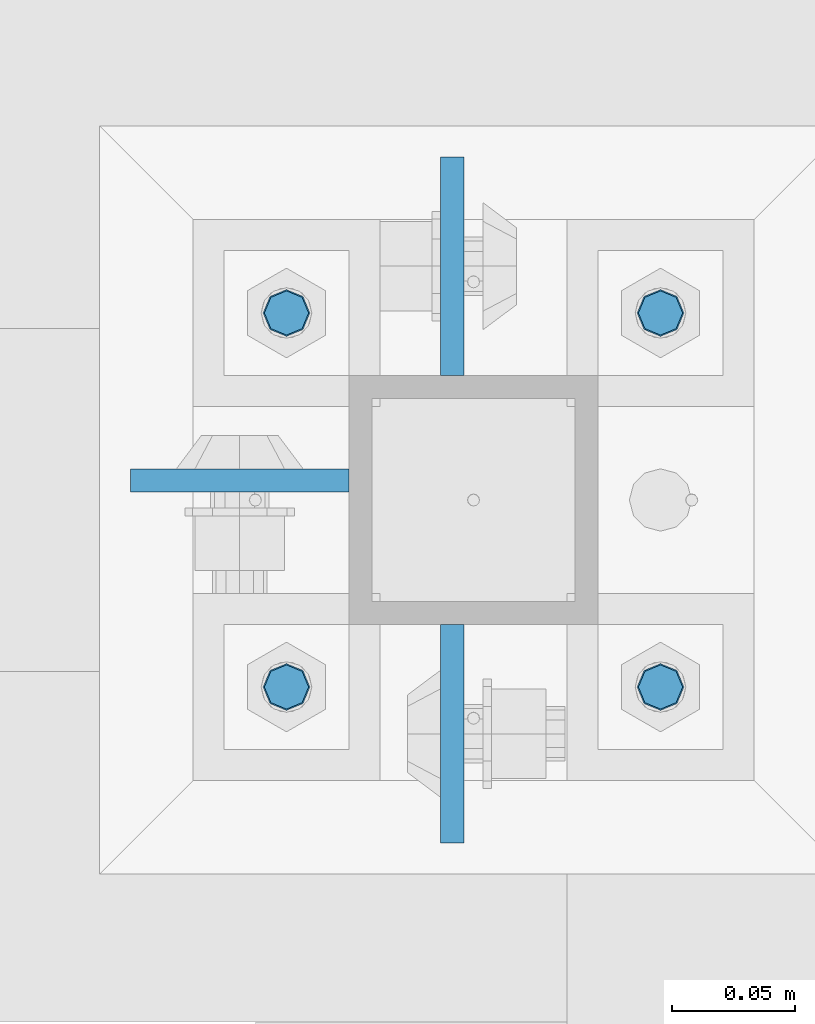
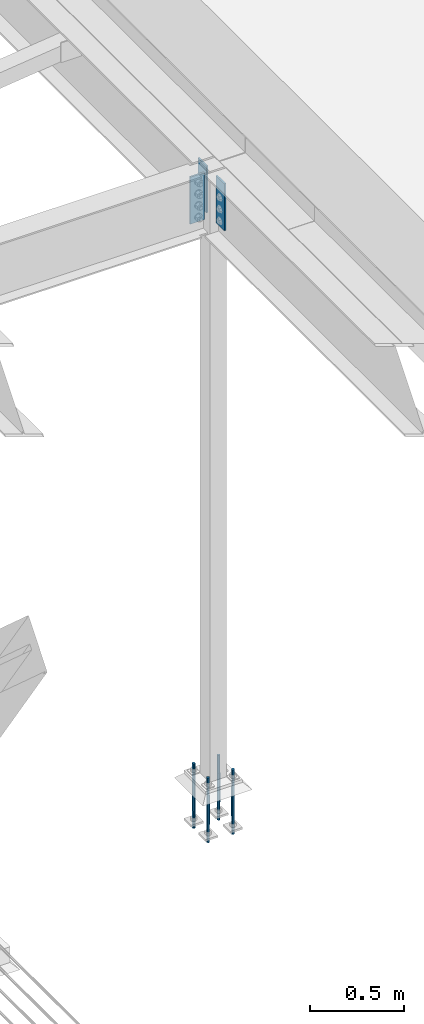
# One storey, part 1557 of 3843: 7 columns, 2 elements without a shape of their own.
"""IFC2X3 building model written with IfcOpenShell, lengths in millimetres."""

from ifc_helpers import new_model, si_unit, frame, origin_with_axes, place, context, subcontext, project, spatial, faceted_brep, material, type_object, element, aggregate, save


model = new_model("IFC2X3")

# Units and contexts
model_context = context("Model", 3, precision=1e-05, world=origin_with_axes())
body_context = subcontext(model_context, "Body", "Model", "MODEL_VIEW")
ifc_project = project(units=[si_unit("LENGTHUNIT", "METRE", prefix="MILLI"), si_unit("AREAUNIT", "SQUARE_METRE"), si_unit("VOLUMEUNIT", "CUBIC_METRE"), si_unit("MASSUNIT", "GRAM", prefix="KILO"), si_unit("TIMEUNIT", "SECOND"), si_unit("PLANEANGLEUNIT", "RADIAN"), si_unit("SOLIDANGLEUNIT", "STERADIAN"), si_unit("THERMODYNAMICTEMPERATUREUNIT", "DEGREE_CELSIUS"), si_unit("LUMINOUSINTENSITYUNIT", "LUMEN")], contexts=[model_context])

# Site, building, storey
site_placement = place(None, origin_with_axes())
site = spatial("IfcSite", under=ifc_project, at=site_placement, CompositionType="ELEMENT")
building_placement = place(site_placement, origin_with_axes())
building = spatial("IfcBuilding", under=site, at=building_placement, Name="Undefined", CompositionType="ELEMENT")
storey_placement = place(building_placement, origin_with_axes())
storey = spatial("IfcBuildingStorey", under=building, at=storey_placement, Name="Undefined", CompositionType="ELEMENT", Elevation=0.0)

# Assembly, columns
assembly_1_placement = place(storey_placement, origin_with_axes())
assembly_1 = element("IfcElementAssembly", 1, at=assembly_1_placement, inside=storey, Name="COLUMN", AssemblyPlace="NOTDEFINED", PredefinedType="RIGID_FRAME")
ifc_material_1 = material(Name="STEEL/A572-50")
column_type_1 = type_object("IfcColumnType", PredefinedType="NOTDEFINED")
column_1_placement = place(assembly_1_placement, frame((38811.9945000649, 75533.25, 33693.0999993376), z_axis=(0.0, 1.0, 0.0), x_axis=(0.0, 0.0, 1.0)))
column_1 = element("IfcColumn", 2, at=column_1_placement, type_object=column_type_1, material=ifc_material_1, Name="PLATE", context=body_context, shape_type="Brep", body=[
    faceted_brep([(0.0, 4.76249999999709, -44.4500000000007), (0.0, 4.76249999999709, 44.4500000000007), (304.799999999996, 4.76249999999709, 44.4500000000007), (304.799999999996, 4.76249999999709, -44.4500000000007), (0.0, -4.76249999999709, 44.4500000000007), (304.799999999996, -4.76249999999709, 44.4500000000007), (0.0, -4.76249999999709, -44.4500000000007), (304.799999999996, -4.76249999999709, -44.4500000000007)], [[[0, 1, 2, 3]], [[1, 4, 5, 2]], [[4, 6, 7, 5]], [[6, 0, 3, 7]], [[5, 7, 3, 2]], [[6, 4, 1, 0]]]),
])
column_2_placement = place(assembly_1_placement, frame((38811.9945000649, 75723.75, 33693.0999993376), z_axis=(0.0, -1.0, 0.0), x_axis=(0.0, 0.0, 1.0)))
column_2 = element("IfcColumn", 3, at=column_2_placement, type_object=column_type_1, material=ifc_material_1, Name="PLATE", context=body_context, shape_type="Brep", body=[
    faceted_brep([(0.0, 4.76249999999709, -44.4500000000007), (0.0, 4.76249999999709, 44.4500000000007), (304.799999999996, 4.76249999999709, 44.4500000000007), (304.799999999996, 4.76249999999709, -44.4500000000007), (0.0, -4.76249999999709, 44.4500000000007), (304.799999999996, -4.76249999999709, 44.4500000000007), (0.0, -4.76249999999709, -44.4500000000007), (304.799999999996, -4.76249999999709, -44.4500000000007)], [[[0, 1, 2, 3]], [[1, 4, 5, 2]], [[4, 6, 7, 5]], [[6, 0, 3, 7]], [[5, 7, 3, 2]], [[6, 4, 1, 0]]]),
])
column_3_placement = place(assembly_1_placement, frame((38725.475, 75636.4374999523, 33693.1), z_axis=(1.0, 0.0, 0.0), x_axis=(0.0, 0.0, 1.0)))
column_3 = element("IfcColumn", 4, at=column_3_placement, type_object=column_type_1, material=ifc_material_1, Name="PLATE", context=body_context, shape_type="Brep", body=[
    faceted_brep([(0.0, 4.76249999999709, -44.4500000000007), (0.0, 4.76249999999709, 44.4500000000007), (304.799999999996, 4.76249999999709, 44.4500000000007), (304.799999999996, 4.76249999999709, -44.4500000000007), (0.0, -4.76249999999709, 44.4500000000007), (304.799999999996, -4.76249999999709, 44.4500000000007), (0.0, -4.76249999999709, -44.4500000000007), (304.799999999996, -4.76249999999709, -44.4500000000007)], [[[0, 1, 2, 3]], [[1, 4, 5, 2]], [[4, 6, 7, 5]], [[6, 0, 3, 7]], [[5, 7, 3, 2]], [[6, 4, 1, 0]]]),
])
aggregate(assembly_1, [column_1, column_2, column_3])

assembly_2_placement = place(storey_placement, origin_with_axes())
assembly_2 = element("IfcElementAssembly", 5, at=assembly_2_placement, inside=storey, Name="TEMPLATE", AssemblyPlace="NOTDEFINED", PredefinedType="RIGID_FRAME")
ifc_material_2 = material(Name="Undefined/F1554-GR.55")
column_type_2 = type_object("IfcColumnType", PredefinedType="NOTDEFINED")
column_4_placement = place(assembly_2_placement, frame((38896.925, 75552.3, 30022.8), z_axis=(1.0, 0.0, 0.0), x_axis=(0.0, 0.0, -1.0)))
column_4 = element("IfcColumn", 6, at=column_4_placement, type_object=column_type_2, material=ifc_material_2, Name="ANCHOR_ROD", context=body_context, shape_type="Brep", body=[
    faceted_brep([(-114.300000000003, -6.36396103068546, 6.36396103067818), (-114.300000000003, 0.0, 9.0), (-114.300000000003, 6.36396103068546, 6.36396103067818), (-114.300000000003, 9.0, 0.0), (-114.300000000003, 6.36396103068546, -6.36396103067818), (-114.300000000003, 0.0, -9.0), (-114.300000000003, -6.36396103068546, -6.36396103067818), (-114.300000000003, -9.0, 0.0), (0.0, 6.36396103068546, -6.36396103067818), (0.0, 0.0, -9.0), (0.0, -6.36396103068546, -6.36396103067818), (0.0, -9.0, 0.0), (0.0, -6.36396103068546, 6.36396103067818), (0.0, 0.0, 9.0), (0.0, 6.36396103068546, 6.36396103067818), (0.0, 9.0, 0.0), (0.0, -6.73519209080405, 6.73519209079677), (-9.87109982941227e-13, 2.91322521661641e-12, 9.52499961853027), (0.0, 6.73519209080405, 6.73519209079677), (0.0, 9.52500000000146, 0.0), (0.0, 6.73519209080405, -6.73519209079677), (2.95075507493764e-12, 2.91322521661641e-12, -9.52499961853027), (0.0, -6.73519209080405, -6.73519209079677), (0.0, -9.52500000000146, 0.0), (190.5, -9.52499999999418, 0.0), (190.5, -6.73519209079677, 6.73519209080405), (190.5, 0.0, 9.52500000000146), (190.5, 6.73519209079677, 6.73519209080405), (190.5, 9.52499999999418, 0.0), (190.5, 6.73519209079677, -6.73519209080405), (190.5, 0.0, -9.52500000000146), (190.5, -6.73519209079677, -6.73519209080405), (190.5, -6.36396103068546, 6.36396103067818), (190.5, 0.0, 9.0), (190.5, 6.36396103068546, 6.36396103067818), (190.5, 9.0, 0.0), (190.5, 6.36396103068546, -6.36396103067818), (190.5, 0.0, -9.0), (190.5, -6.36396103068546, -6.36396103067818), (190.5, -9.0, 0.0), (304.799999999999, 0.0, -9.0), (304.799999999999, 6.36396103068546, -6.36396103067818), (304.799999999999, 9.0, 0.0), (304.799999999999, 6.36396103068546, 6.36396103067818), (304.799999999999, 0.0, 9.0), (304.799999999999, -6.36396103068546, 6.36396103067818), (304.799999999999, -9.0, 0.0), (304.799999999999, -6.36396103068546, -6.36396103067818)], [[[0, 1, 2, 3, 4, 5, 6, 7]], [[5, 4, 8, 9]], [[6, 5, 9, 10]], [[7, 6, 10, 11]], [[0, 7, 11, 12]], [[1, 0, 12, 13]], [[2, 1, 13, 14]], [[3, 2, 14, 15]], [[4, 3, 15, 8]], [[16, 17, 18, 19, 20, 21, 22, 23], [14, 13, 12, 11, 10, 9, 8, 15]], [[16, 23, 24, 25]], [[17, 16, 25, 26]], [[18, 17, 26, 27]], [[19, 18, 27, 28]], [[20, 19, 28, 29]], [[21, 20, 29, 30]], [[22, 21, 30, 31]], [[23, 22, 31, 24]], [[30, 29, 28, 27, 26, 25, 24, 31], [32, 33, 34, 35, 36, 37, 38, 39]], [[40, 41, 42, 43, 44, 45, 46, 47]], [[45, 44, 33, 32]], [[46, 45, 32, 39]], [[47, 46, 39, 38]], [[40, 47, 38, 37]], [[41, 40, 37, 36]], [[42, 41, 36, 35]], [[43, 42, 35, 34]], [[44, 43, 34, 33]]]),
])
column_5_placement = place(assembly_2_placement, frame((38896.925, 75704.7, 30022.8), z_axis=(-1.0, 0.0, 0.0), x_axis=(0.0, 0.0, -1.0)))
column_5 = element("IfcColumn", 7, at=column_5_placement, type_object=column_type_2, material=ifc_material_2, Name="ANCHOR_ROD", context=body_context, shape_type="Brep", body=[
    faceted_brep([(-114.300000000003, -6.36396103068546, 6.36396103067818), (-114.300000000003, 0.0, 9.0), (-114.300000000003, 6.36396103068546, 6.36396103067818), (-114.300000000003, 9.0, 0.0), (-114.300000000003, 6.36396103068546, -6.36396103067818), (-114.300000000003, 0.0, -9.0), (-114.300000000003, -6.36396103068546, -6.36396103067818), (-114.300000000003, -9.0, 0.0), (0.0, 6.36396103068546, -6.36396103067818), (0.0, 0.0, -9.0), (0.0, -6.36396103068546, -6.36396103067818), (0.0, -9.0, 0.0), (0.0, -6.36396103068546, 6.36396103067818), (0.0, 0.0, 9.0), (0.0, 6.36396103068546, 6.36396103067818), (0.0, 9.0, 0.0), (0.0, -6.73519209080405, 6.73519209079677), (-9.87109982941227e-13, 2.91322521661641e-12, 9.52499961853027), (0.0, 6.73519209080405, 6.73519209079677), (0.0, 9.52500000000146, 0.0), (0.0, 6.73519209080405, -6.73519209079677), (2.95075507493764e-12, 2.91322521661641e-12, -9.52499961853027), (0.0, -6.73519209080405, -6.73519209079677), (0.0, -9.52500000000146, 0.0), (190.5, -9.52499999999418, 0.0), (190.5, -6.73519209079677, 6.73519209080405), (190.5, 0.0, 9.52500000000146), (190.5, 6.73519209079677, 6.73519209080405), (190.5, 9.52499999999418, 0.0), (190.5, 6.73519209079677, -6.73519209080405), (190.5, 0.0, -9.52500000000146), (190.5, -6.73519209079677, -6.73519209080405), (190.5, -6.36396103068546, 6.36396103067818), (190.5, 0.0, 9.0), (190.5, 6.36396103068546, 6.36396103067818), (190.5, 9.0, 0.0), (190.5, 6.36396103068546, -6.36396103067818), (190.5, 0.0, -9.0), (190.5, -6.36396103068546, -6.36396103067818), (190.5, -9.0, 0.0), (304.799999999999, 0.0, -9.0), (304.799999999999, 6.36396103068546, -6.36396103067818), (304.799999999999, 9.0, 0.0), (304.799999999999, 6.36396103068546, 6.36396103067818), (304.799999999999, 0.0, 9.0), (304.799999999999, -6.36396103068546, 6.36396103067818), (304.799999999999, -9.0, 0.0), (304.799999999999, -6.36396103068546, -6.36396103067818)], [[[0, 1, 2, 3, 4, 5, 6, 7]], [[5, 4, 8, 9]], [[6, 5, 9, 10]], [[7, 6, 10, 11]], [[0, 7, 11, 12]], [[1, 0, 12, 13]], [[2, 1, 13, 14]], [[3, 2, 14, 15]], [[4, 3, 15, 8]], [[16, 17, 18, 19, 20, 21, 22, 23], [14, 13, 12, 11, 10, 9, 8, 15]], [[16, 23, 24, 25]], [[17, 16, 25, 26]], [[18, 17, 26, 27]], [[19, 18, 27, 28]], [[20, 19, 28, 29]], [[21, 20, 29, 30]], [[22, 21, 30, 31]], [[23, 22, 31, 24]], [[30, 29, 28, 27, 26, 25, 24, 31], [32, 33, 34, 35, 36, 37, 38, 39]], [[40, 41, 42, 43, 44, 45, 46, 47]], [[45, 44, 33, 32]], [[46, 45, 32, 39]], [[47, 46, 39, 38]], [[40, 47, 38, 37]], [[41, 40, 37, 36]], [[42, 41, 36, 35]], [[43, 42, 35, 34]], [[44, 43, 34, 33]]]),
])
column_6_placement = place(assembly_2_placement, frame((38744.525, 75552.3, 30022.8), z_axis=(1.0, 0.0, 0.0), x_axis=(0.0, 0.0, -1.0)))
column_6 = element("IfcColumn", 8, at=column_6_placement, type_object=column_type_2, material=ifc_material_2, Name="ANCHOR_ROD", context=body_context, shape_type="Brep", body=[
    faceted_brep([(-114.300000000003, -6.36396103068546, 6.36396103067818), (-114.300000000003, 0.0, 9.0), (-114.300000000003, 6.36396103068546, 6.36396103067818), (-114.300000000003, 9.0, 0.0), (-114.300000000003, 6.36396103068546, -6.36396103067818), (-114.300000000003, 0.0, -9.0), (-114.300000000003, -6.36396103068546, -6.36396103067818), (-114.300000000003, -9.0, 0.0), (0.0, 6.36396103068546, -6.36396103067818), (0.0, 0.0, -9.0), (0.0, -6.36396103068546, -6.36396103067818), (0.0, -9.0, 0.0), (0.0, -6.36396103068546, 6.36396103067818), (0.0, 0.0, 9.0), (0.0, 6.36396103068546, 6.36396103067818), (0.0, 9.0, 0.0), (0.0, -6.73519209080405, 6.73519209079677), (-9.87109982941227e-13, 2.91322521661641e-12, 9.52499961853027), (0.0, 6.73519209080405, 6.73519209079677), (0.0, 9.52500000000146, 0.0), (0.0, 6.73519209080405, -6.73519209079677), (2.95075507493764e-12, 2.91322521661641e-12, -9.52499961853027), (0.0, -6.73519209080405, -6.73519209079677), (0.0, -9.52500000000146, 0.0), (190.5, -9.52499999999418, 0.0), (190.5, -6.73519209079677, 6.73519209080405), (190.5, 0.0, 9.52500000000146), (190.5, 6.73519209079677, 6.73519209080405), (190.5, 9.52499999999418, 0.0), (190.5, 6.73519209079677, -6.73519209080405), (190.5, 0.0, -9.52500000000146), (190.5, -6.73519209079677, -6.73519209080405), (190.5, -6.36396103068546, 6.36396103067818), (190.5, 0.0, 9.0), (190.5, 6.36396103068546, 6.36396103067818), (190.5, 9.0, 0.0), (190.5, 6.36396103068546, -6.36396103067818), (190.5, 0.0, -9.0), (190.5, -6.36396103068546, -6.36396103067818), (190.5, -9.0, 0.0), (304.799999999999, 0.0, -9.0), (304.799999999999, 6.36396103068546, -6.36396103067818), (304.799999999999, 9.0, 0.0), (304.799999999999, 6.36396103068546, 6.36396103067818), (304.799999999999, 0.0, 9.0), (304.799999999999, -6.36396103068546, 6.36396103067818), (304.799999999999, -9.0, 0.0), (304.799999999999, -6.36396103068546, -6.36396103067818)], [[[0, 1, 2, 3, 4, 5, 6, 7]], [[5, 4, 8, 9]], [[6, 5, 9, 10]], [[7, 6, 10, 11]], [[0, 7, 11, 12]], [[1, 0, 12, 13]], [[2, 1, 13, 14]], [[3, 2, 14, 15]], [[4, 3, 15, 8]], [[16, 17, 18, 19, 20, 21, 22, 23], [14, 13, 12, 11, 10, 9, 8, 15]], [[16, 23, 24, 25]], [[17, 16, 25, 26]], [[18, 17, 26, 27]], [[19, 18, 27, 28]], [[20, 19, 28, 29]], [[21, 20, 29, 30]], [[22, 21, 30, 31]], [[23, 22, 31, 24]], [[30, 29, 28, 27, 26, 25, 24, 31], [32, 33, 34, 35, 36, 37, 38, 39]], [[40, 41, 42, 43, 44, 45, 46, 47]], [[45, 44, 33, 32]], [[46, 45, 32, 39]], [[47, 46, 39, 38]], [[40, 47, 38, 37]], [[41, 40, 37, 36]], [[42, 41, 36, 35]], [[43, 42, 35, 34]], [[44, 43, 34, 33]]]),
])
column_7_placement = place(assembly_2_placement, frame((38744.525, 75704.7, 30022.8), z_axis=(-1.0, 0.0, 0.0), x_axis=(0.0, 0.0, -1.0)))
column_7 = element("IfcColumn", 9, at=column_7_placement, type_object=column_type_2, material=ifc_material_2, Name="ANCHOR_ROD", context=body_context, shape_type="Brep", body=[
    faceted_brep([(-114.300000000003, -6.36396103068546, 6.36396103067818), (-114.300000000003, 0.0, 9.0), (-114.300000000003, 6.36396103068546, 6.36396103067818), (-114.300000000003, 9.0, 0.0), (-114.300000000003, 6.36396103068546, -6.36396103067818), (-114.300000000003, 0.0, -9.0), (-114.300000000003, -6.36396103068546, -6.36396103067818), (-114.300000000003, -9.0, 0.0), (0.0, 6.36396103068546, -6.36396103067818), (0.0, 0.0, -9.0), (0.0, -6.36396103068546, -6.36396103067818), (0.0, -9.0, 0.0), (0.0, -6.36396103068546, 6.36396103067818), (0.0, 0.0, 9.0), (0.0, 6.36396103068546, 6.36396103067818), (0.0, 9.0, 0.0), (0.0, -6.73519209080405, 6.73519209079677), (-9.87109982941227e-13, 2.91322521661641e-12, 9.52499961853027), (0.0, 6.73519209080405, 6.73519209079677), (0.0, 9.52500000000146, 0.0), (0.0, 6.73519209080405, -6.73519209079677), (2.95075507493764e-12, 2.91322521661641e-12, -9.52499961853027), (0.0, -6.73519209080405, -6.73519209079677), (0.0, -9.52500000000146, 0.0), (190.5, -9.52499999999418, 0.0), (190.5, -6.73519209079677, 6.73519209080405), (190.5, 0.0, 9.52500000000146), (190.5, 6.73519209079677, 6.73519209080405), (190.5, 9.52499999999418, 0.0), (190.5, 6.73519209079677, -6.73519209080405), (190.5, 0.0, -9.52500000000146), (190.5, -6.73519209079677, -6.73519209080405), (190.5, -6.36396103068546, 6.36396103067818), (190.5, 0.0, 9.0), (190.5, 6.36396103068546, 6.36396103067818), (190.5, 9.0, 0.0), (190.5, 6.36396103068546, -6.36396103067818), (190.5, 0.0, -9.0), (190.5, -6.36396103068546, -6.36396103067818), (190.5, -9.0, 0.0), (304.799999999999, 0.0, -9.0), (304.799999999999, 6.36396103068546, -6.36396103067818), (304.799999999999, 9.0, 0.0), (304.799999999999, 6.36396103068546, 6.36396103067818), (304.799999999999, 0.0, 9.0), (304.799999999999, -6.36396103068546, 6.36396103067818), (304.799999999999, -9.0, 0.0), (304.799999999999, -6.36396103068546, -6.36396103067818)], [[[0, 1, 2, 3, 4, 5, 6, 7]], [[5, 4, 8, 9]], [[6, 5, 9, 10]], [[7, 6, 10, 11]], [[0, 7, 11, 12]], [[1, 0, 12, 13]], [[2, 1, 13, 14]], [[3, 2, 14, 15]], [[4, 3, 15, 8]], [[16, 17, 18, 19, 20, 21, 22, 23], [14, 13, 12, 11, 10, 9, 8, 15]], [[16, 23, 24, 25]], [[17, 16, 25, 26]], [[18, 17, 26, 27]], [[19, 18, 27, 28]], [[20, 19, 28, 29]], [[21, 20, 29, 30]], [[22, 21, 30, 31]], [[23, 22, 31, 24]], [[30, 29, 28, 27, 26, 25, 24, 31], [32, 33, 34, 35, 36, 37, 38, 39]], [[40, 41, 42, 43, 44, 45, 46, 47]], [[45, 44, 33, 32]], [[46, 45, 32, 39]], [[47, 46, 39, 38]], [[40, 47, 38, 37]], [[41, 40, 37, 36]], [[42, 41, 36, 35]], [[43, 42, 35, 34]], [[44, 43, 34, 33]]]),
])
aggregate(assembly_2, [column_4, column_5, column_6, column_7])

save(model, "model.ifc")
